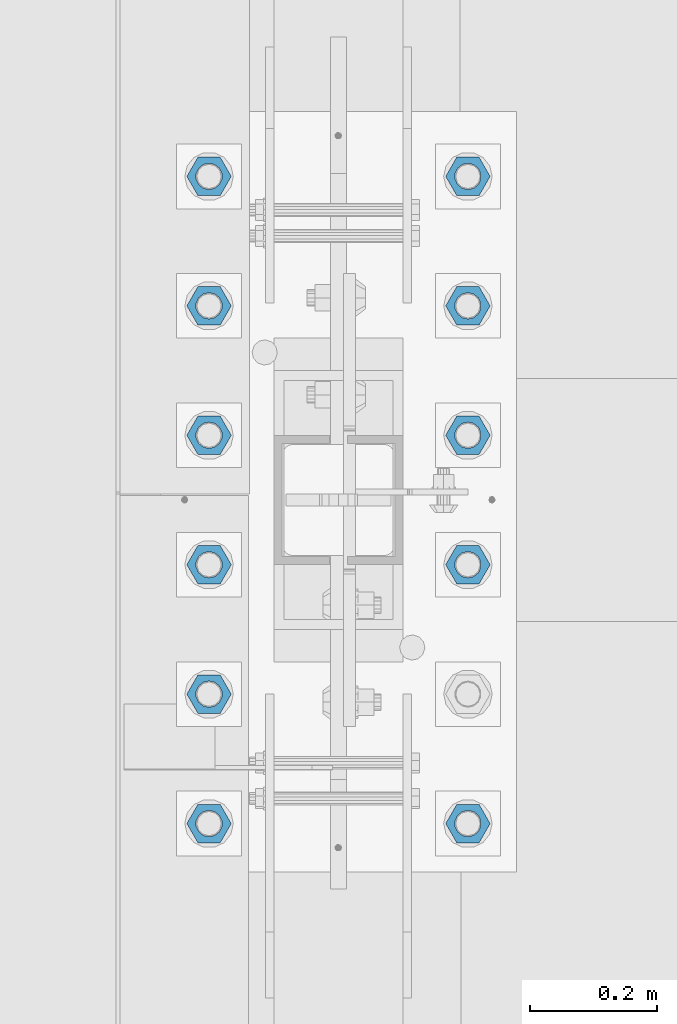
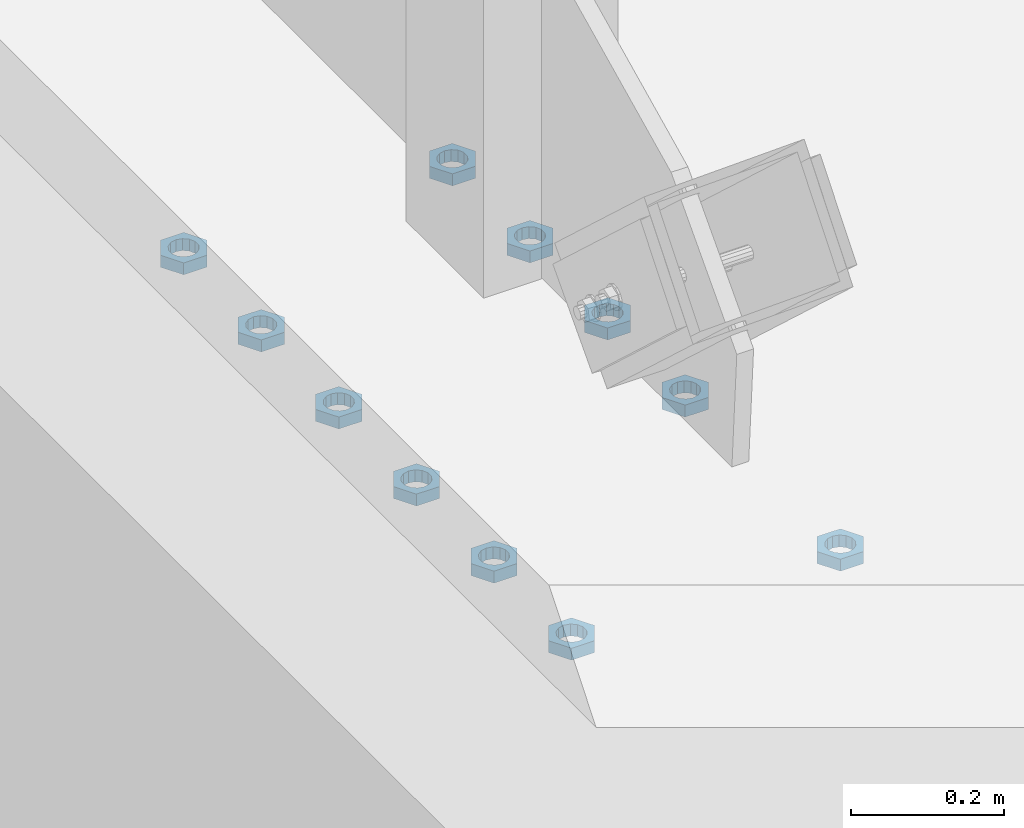
# One storey, part 1389 of 1763: 11 beams, 1 element without a shape of its own.
"""IFC2X3 building model written with IfcOpenShell, lengths in millimetres."""

import ifcopenshell
import ifcopenshell.guid

model = None  # the IFC model being written
_history = None  # IfcOwnerHistory: only IFC2X3 demands one
_inside = {}  # id of a spatial element -> (the spatial element, [elements in it])
_under = {}  # id of a project, library or spatial element -> (it, [spatial elements below it])
_declared = {}  # id of a project -> (the project, [libraries it declares])
_typed = {}  # id of a type object -> (the type object, [elements of that type])
_made_of = {}  # id of a material, layer set ... -> (it, [elements and type objects made of it])


def new_model(schema):
    """Start an empty IFC model of exactly this schema.

    Asked for "IFC4X3", IfcOpenShell would pick the latest addendum, in which some entities
    have other attributes; the version numbers below select the first issue.
    IFC2X3 requires an IfcOwnerHistory on every rooted entity: one is made here for all.
    """
    global model, _history
    if schema == "IFC4X3":
        model = ifcopenshell.file(schema_version=(4, 3, 0, 0))
    else:
        model = ifcopenshell.file(schema=schema)
    _inside.clear()
    _under.clear()
    _declared.clear()
    _typed.clear()
    _made_of.clear()
    _history = None
    if model.schema == "IFC2X3":
        org = make("IfcOrganization", Name="unknown")
        user = make(
            "IfcPersonAndOrganization",
            ThePerson=make("IfcPerson", FamilyName="unknown"),
            TheOrganization=org,
        )
        app = make(
            "IfcApplication",
            ApplicationDeveloper=org,
            Version="unknown",
            ApplicationFullName="unknown",
            ApplicationIdentifier="unknown",
        )
        _history = make(
            "IfcOwnerHistory",
            OwningUser=user,
            OwningApplication=app,
            ChangeAction="ADDED",
            CreationDate=0,
        )
    return model


def make(cls, **values):
    """One entity of the class cls with the attributes given. An attribute that is None is left unset."""
    return model.create_entity(
        cls, **{name: value for name, value in values.items() if value is not None}
    )


def rooted(cls, **values):
    """An entity with a GlobalId (a new one), such as an element, a storey or a relation."""
    return make(cls, GlobalId=ifcopenshell.guid.new(), OwnerHistory=_history, **values)


def si_unit(unit_type, name, prefix=None):
    """IfcSIUnit, for example si_unit("LENGTHUNIT", "METRE", prefix="MILLI")."""
    return make("IfcSIUnit", UnitType=unit_type, Prefix=prefix, Name=name)


def assignment(units):
    """IfcUnitAssignment: the units of a project."""
    return None if units is None else make("IfcUnitAssignment", Units=units)


def point(xyz):
    """IfcCartesianPoint."""
    return None if xyz is None else make("IfcCartesianPoint", Coordinates=xyz)


def direction(xyz):
    """IfcDirection."""
    return None if xyz is None else make("IfcDirection", DirectionRatios=xyz)


def frame(location, z_axis=None, x_axis=None):
    """IfcAxis2Placement3D, a coordinate frame: its origin and axes. An axis left out is left unset."""
    return make(
        "IfcAxis2Placement3D",
        Location=point(location),
        Axis=direction(z_axis),
        RefDirection=direction(x_axis),
    )


def origin_with_axes():
    """The frame at (0, 0, 0) with the z axis (0, 0, 1) and the x axis (1, 0, 0) written out."""
    return frame((0.0, 0.0, 0.0), z_axis=(0.0, 0.0, 1.0), x_axis=(1.0, 0.0, 0.0))


def place(relative_to, where):
    """IfcLocalPlacement: puts the frame where relative to a parent placement (None: the world)."""
    return make(
        "IfcLocalPlacement", PlacementRelTo=relative_to, RelativePlacement=where
    )


def context(
    kind, dimensions, precision=None, world=None, true_north=None, identifier=None
):
    """IfcGeometricRepresentationContext, for example the 3D "Model" context."""
    return make(
        "IfcGeometricRepresentationContext",
        ContextIdentifier=identifier,
        ContextType=kind,
        CoordinateSpaceDimension=dimensions,
        Precision=precision,
        WorldCoordinateSystem=world,
        TrueNorth=true_north,
    )


def subcontext(parent, identifier, kind, view, scale=None):
    """IfcGeometricRepresentationSubContext, for example "Body" below "Model"."""
    return make(
        "IfcGeometricRepresentationSubContext",
        ContextIdentifier=identifier,
        ContextType=kind,
        ParentContext=parent,
        TargetScale=scale,
        TargetView=view,
    )


def project(units=None, contexts=None):
    """IfcProject with its units and contexts."""
    return rooted(
        "IfcProject",
        Name="project",
        RepresentationContexts=contexts,
        UnitsInContext=assignment(units),
    )


def spatial(cls, under=None, at=None, **own):
    """A site, building, storey or space (cls), placed at a placement, below another one or the project."""
    s = rooted(cls, ObjectPlacement=at, **own)
    if under is not None:
        _under.setdefault(under.id(), (under, []))[1].append(s)
    return s


def faces_of(points, faces, orient=None, outer=None):
    """IfcFace entities. A face is a list of loops; a loop is a list of indices into points, from 0.

    orient and outer hold one flag for each loop. By default every Orientation is true, the
    first loop of a face is its IfcFaceOuterBound and the others are IfcFaceBound.
    """
    made = []
    for i, loops in enumerate(faces):
        bounds = []
        for j, loop in enumerate(loops):
            is_outer = j == 0 if outer is None else outer[i][j]
            bounds.append(
                make(
                    "IfcFaceOuterBound" if is_outer else "IfcFaceBound",
                    Bound=make("IfcPolyLoop", Polygon=[points[k] for k in loop]),
                    Orientation=True if orient is None else orient[i][j],
                )
            )
        made.append(make("IfcFace", Bounds=bounds))
    return made


def faceted_brep(points, faces, orient=None, outer=None, voids=None):
    """IfcFacetedBrep: a solid bounded by flat faces; with voids (closed shells), ...WithVoids."""
    shared = [point(p) for p in points]
    hull = make("IfcClosedShell", CfsFaces=faces_of(shared, faces, orient, outer))
    if voids is None:
        return make("IfcFacetedBrep", Outer=hull)
    return make(
        "IfcFacetedBrepWithVoids",
        Outer=hull,
        Voids=[
            make(cls, CfsFaces=faces_of(shared, fs, o, b)) for cls, fs, o, b in voids
        ],
    )


def shape(context_of_items, identifier, shape_type, items):
    """IfcShapeRepresentation: the items that make up one representation, for example the "Body"."""
    return make(
        "IfcShapeRepresentation",
        ContextOfItems=context_of_items,
        RepresentationIdentifier=identifier,
        RepresentationType=shape_type,
        Items=items,
    )


def material(Name=None, Category=None):
    """IfcMaterial."""
    return make("IfcMaterial", Name=Name, Category=Category)


def made_of(thing, what):
    """Note that an element or type object is made of a material, layer set ...; save() writes the relation."""
    if what is not None:
        _made_of.setdefault(what.id(), (what, []))[1].append(thing)
    return thing


def type_object(cls, material=None, **own):
    """A type object (cls), such as IfcWallType, which elements share."""
    return made_of(rooted(cls, **own), material)


def element(
    cls,
    number,
    at=None,
    inside=None,
    cuts=None,
    type_object=None,
    material=None,
    context=None,
    identifier="Body",
    shape_type=None,
    held_by="IfcProductDefinitionShape",
    body=None,
    shapes=None,
    **own,
):
    """One element of the class cls, such as IfcWall. Its Tag is "e" and its number.

    at: its placement. inside: the storey or other place that contains it. cuts: it is an
    opening in that element (IfcRelVoidsElement). A single representation is given by context,
    identifier, shape_type and body (its items); several are given by shapes. held_by: the class
    of the entity that holds the representations. save() writes the other relations.
    """
    e = rooted(cls, Tag="e%d" % number, ObjectPlacement=at, **own)
    if body is not None:
        shapes = [shape(context, identifier, shape_type, body)]
    if shapes is not None:
        e.Representation = make(held_by, Representations=shapes)
    if inside is not None:
        _inside.setdefault(inside.id(), (inside, []))[1].append(e)
    if cuts is not None:
        rooted(
            "IfcRelVoidsElement", RelatingBuildingElement=cuts, RelatedOpeningElement=e
        )
    if type_object is not None:
        _typed.setdefault(type_object.id(), (type_object, []))[1].append(e)
    return made_of(e, material)


def aggregate(whole, parts):
    """IfcRelAggregates: a whole, such as a stair, and the parts it consists of."""
    return rooted("IfcRelAggregates", RelatingObject=whole, RelatedObjects=parts)


def save(model, path):
    """Write the relations noted so far, then the file.

    IfcRelAggregates (storeys below a building ...), IfcRelContainedInSpatialStructure (elements
    in a storey), IfcRelDefinesByType, IfcRelAssociatesMaterial and IfcRelDeclares: one each for
    every whole, place, type object, material and project.
    """
    for whole, parts in _under.values():
        aggregate(whole, parts)
    for where, things in _inside.values():
        rooted(
            "IfcRelContainedInSpatialStructure",
            RelatedElements=things,
            RelatingStructure=where,
        )
    for kind, things in _typed.values():
        rooted("IfcRelDefinesByType", RelatedObjects=things, RelatingType=kind)
    for what, things in _made_of.values():
        rooted("IfcRelAssociatesMaterial", RelatedObjects=things, RelatingMaterial=what)
    for by, libraries in _declared.values():
        rooted("IfcRelDeclares", RelatingContext=by, RelatedDefinitions=libraries)
    model.write(path)


model = new_model("IFC2X3")

# Units and contexts
model_context = context("Model", 3, precision=1e-05, world=origin_with_axes())
body_context = subcontext(model_context, "Body", "Model", "MODEL_VIEW")
ifc_project = project(units=[si_unit("LENGTHUNIT", "METRE", prefix="MILLI"), si_unit("AREAUNIT", "SQUARE_METRE"), si_unit("VOLUMEUNIT", "CUBIC_METRE"), si_unit("MASSUNIT", "GRAM", prefix="KILO"), si_unit("TIMEUNIT", "SECOND"), si_unit("PLANEANGLEUNIT", "RADIAN"), si_unit("SOLIDANGLEUNIT", "STERADIAN"), si_unit("THERMODYNAMICTEMPERATUREUNIT", "DEGREE_CELSIUS"), si_unit("LUMINOUSINTENSITYUNIT", "LUMEN")], contexts=[model_context])

# Site, building, storey
site_placement = place(None, origin_with_axes())
site = spatial("IfcSite", under=ifc_project, at=site_placement, CompositionType="ELEMENT")
building_placement = place(site_placement, origin_with_axes())
building = spatial("IfcBuilding", under=site, at=building_placement, Name="Undefined", CompositionType="ELEMENT")
storey_placement = place(building_placement, origin_with_axes())
storey = spatial("IfcBuildingStorey", under=building, at=storey_placement, Name="Undefined", CompositionType="ELEMENT", Elevation=0.0)

# Assembly, beams
assembly_placement = place(storey_placement, origin_with_axes())
assembly = element("IfcElementAssembly", 1, at=assembly_placement, inside=storey, Name="TEMPLATE", AssemblyPlace="NOTDEFINED", PredefinedType="RIGID_FRAME")
ifc_material = material(Name="STEEL/A563")
beam_type = type_object("IfcBeamType", Name="1-1/2 DIA. HALF_NUT", PredefinedType="NOTDEFINED")
beam_1_placement = place(assembly_placement, frame((-87578.6372736983, 965.200000000001, 5080.0), z_axis=(0.0, -1.0, 0.0), x_axis=(0.0, 0.0, -1.0)))
beam_1 = element("IfcBeam", 2, at=beam_1_placement, type_object=beam_type, material=ifc_material, Name="NUT", ObjectType="1-1/2 DIA. HALF_NUT", context=body_context, shape_type="Brep", body=[
    faceted_brep([(0.0, -34.9199981689453, 0.0), (0.0, -17.4599990844727, -30.25), (19.0499999999993, -17.4599990844727, -30.25), (19.0499999999993, -34.9199981689453, 0.0), (0.0, 17.4599990844727, -30.25), (19.0499999999993, 17.4599990844727, -30.25), (0.0, 34.9199981689453, 0.0), (19.0499999999993, 34.9199981689453, 0.0), (0.0, 17.4599990844727, 30.25), (19.0499999999993, 17.4599990844727, 30.25), (0.0, -17.4599990844727, 30.25), (19.0499999999993, -17.4599990844727, 30.25), (0.0, 0.0, 20.6399993896484), (0.0, 8.95536011056538, 18.5959968835978), (19.0499999999993, 8.95536011056538, 18.5959968835978), (19.0499999999993, 0.0, 20.6399993896484), (0.0, 16.1370013209453, 12.8688291298167), (19.0499999999993, 16.1370013209453, 12.8688291298167), (0.0, 20.1225115123816, 4.59283194104137), (19.0499999999993, 20.1225115123816, 4.59283194104137), (0.0, 20.1225115123816, -4.59283194104319), (19.0499999999993, 20.1225115123816, -4.59283194104319), (0.0, 16.1370013209453, -12.8688291298167), (19.0499999999993, 16.1370013209453, -12.8688291298167), (0.0, 8.95536011056538, -18.5959968835978), (19.0499999999993, 8.95536011056538, -18.5959968835978), (0.0, 0.0, -20.6399993896484), (19.0499999999993, 0.0, -20.6399993896484), (0.0, -8.95536011056538, -18.5959968835978), (19.0499999999993, -8.95536011056538, -18.5959968835978), (0.0, -16.1370013209453, -12.8688291298167), (19.0499999999993, -16.1370013209453, -12.8688291298167), (0.0, -20.1225115123816, -4.59283194104137), (19.0499999999993, -20.1225115123816, -4.59283194104137), (0.0, -20.1225115123816, 4.59283194104319), (19.0499999999993, -20.1225115123816, 4.59283194104319), (0.0, -16.1370013209453, 12.8688291298167), (19.0499999999993, -16.1370013209453, 12.8688291298167), (0.0, -8.95536011056538, 18.5959968835978), (19.0499999999993, -8.95536011056538, 18.5959968835978)], [[[0, 1, 2, 3]], [[1, 4, 5, 2]], [[4, 6, 7, 5]], [[6, 8, 9, 7]], [[8, 10, 11, 9]], [[10, 0, 3, 11]], [[12, 13, 14, 15]], [[13, 16, 17, 14]], [[16, 18, 19, 17]], [[18, 20, 21, 19]], [[20, 22, 23, 21]], [[22, 24, 25, 23]], [[24, 26, 27, 25]], [[26, 28, 29, 27]], [[28, 30, 31, 29]], [[30, 32, 33, 31]], [[32, 34, 35, 33]], [[34, 36, 37, 35]], [[36, 38, 39, 37]], [[38, 12, 15, 39]], [[5, 7, 9, 11, 3, 2], [17, 19, 21, 23, 25, 27, 29, 31, 33, 35, 37, 39, 15, 14]], [[10, 8, 6, 4, 1, 0], [38, 36, 34, 32, 30, 28, 26, 24, 22, 20, 18, 16, 13, 12]]]),
])
beam_2_placement = place(assembly_placement, frame((-87578.6372736983, 762.000000000001, 5080.0), z_axis=(0.0, -1.0, 0.0), x_axis=(0.0, 0.0, -1.0)))
beam_2 = element("IfcBeam", 3, at=beam_2_placement, type_object=beam_type, material=ifc_material, Name="NUT", ObjectType="1-1/2 DIA. HALF_NUT", context=body_context, shape_type="Brep", body=[
    faceted_brep([(0.0, -34.9199981689453, 0.0), (0.0, -17.4599990844727, -30.25), (19.0499999999993, -17.4599990844727, -30.25), (19.0499999999993, -34.9199981689453, 0.0), (0.0, 17.4599990844727, -30.25), (19.0499999999993, 17.4599990844727, -30.25), (0.0, 34.9199981689453, 0.0), (19.0499999999993, 34.9199981689453, 0.0), (0.0, 17.4599990844727, 30.25), (19.0499999999993, 17.4599990844727, 30.25), (0.0, -17.4599990844727, 30.25), (19.0499999999993, -17.4599990844727, 30.25), (0.0, 0.0, 20.6399993896484), (0.0, 8.95536011056538, 18.5959968835978), (19.0499999999993, 8.95536011056538, 18.5959968835978), (19.0499999999993, 0.0, 20.6399993896484), (0.0, 16.1370013209453, 12.8688291298167), (19.0499999999993, 16.1370013209453, 12.8688291298167), (0.0, 20.1225115123816, 4.59283194104137), (19.0499999999993, 20.1225115123816, 4.59283194104137), (0.0, 20.1225115123816, -4.59283194104319), (19.0499999999993, 20.1225115123816, -4.59283194104319), (0.0, 16.1370013209453, -12.8688291298167), (19.0499999999993, 16.1370013209453, -12.8688291298167), (0.0, 8.95536011056538, -18.5959968835978), (19.0499999999993, 8.95536011056538, -18.5959968835978), (0.0, 0.0, -20.6399993896484), (19.0499999999993, 0.0, -20.6399993896484), (0.0, -8.95536011056538, -18.5959968835978), (19.0499999999993, -8.95536011056538, -18.5959968835978), (0.0, -16.1370013209453, -12.8688291298167), (19.0499999999993, -16.1370013209453, -12.8688291298167), (0.0, -20.1225115123816, -4.59283194104137), (19.0499999999993, -20.1225115123816, -4.59283194104137), (0.0, -20.1225115123816, 4.59283194104319), (19.0499999999993, -20.1225115123816, 4.59283194104319), (0.0, -16.1370013209453, 12.8688291298167), (19.0499999999993, -16.1370013209453, 12.8688291298167), (0.0, -8.95536011056538, 18.5959968835978), (19.0499999999993, -8.95536011056538, 18.5959968835978)], [[[0, 1, 2, 3]], [[1, 4, 5, 2]], [[4, 6, 7, 5]], [[6, 8, 9, 7]], [[8, 10, 11, 9]], [[10, 0, 3, 11]], [[12, 13, 14, 15]], [[13, 16, 17, 14]], [[16, 18, 19, 17]], [[18, 20, 21, 19]], [[20, 22, 23, 21]], [[22, 24, 25, 23]], [[24, 26, 27, 25]], [[26, 28, 29, 27]], [[28, 30, 31, 29]], [[30, 32, 33, 31]], [[32, 34, 35, 33]], [[34, 36, 37, 35]], [[36, 38, 39, 37]], [[38, 12, 15, 39]], [[5, 7, 9, 11, 3, 2], [17, 19, 21, 23, 25, 27, 29, 31, 33, 35, 37, 39, 15, 14]], [[10, 8, 6, 4, 1, 0], [38, 36, 34, 32, 30, 28, 26, 24, 22, 20, 18, 16, 13, 12]]]),
])
beam_3_placement = place(assembly_placement, frame((-87172.2372736984, 965.200000000001, 5080.0), z_axis=(0.0, 1.0, 0.0), x_axis=(0.0, 0.0, -1.0)))
beam_3 = element("IfcBeam", 4, at=beam_3_placement, type_object=beam_type, material=ifc_material, Name="NUT", ObjectType="1-1/2 DIA. HALF_NUT", context=body_context, shape_type="Brep", body=[
    faceted_brep([(0.0, -34.9199981689453, 0.0), (0.0, -17.4599990844727, -30.25), (19.0499999999993, -17.4599990844727, -30.25), (19.0499999999993, -34.9199981689453, 0.0), (0.0, 17.4599990844727, -30.25), (19.0499999999993, 17.4599990844727, -30.25), (0.0, 34.9199981689453, 0.0), (19.0499999999993, 34.9199981689453, 0.0), (0.0, 17.4599990844727, 30.25), (19.0499999999993, 17.4599990844727, 30.25), (0.0, -17.4599990844727, 30.25), (19.0499999999993, -17.4599990844727, 30.25), (0.0, 0.0, 20.6399993896484), (0.0, 8.95536011056538, 18.5959968835978), (19.0499999999993, 8.95536011056538, 18.5959968835978), (19.0499999999993, 0.0, 20.6399993896484), (0.0, 16.1370013209453, 12.8688291298167), (19.0499999999993, 16.1370013209453, 12.8688291298167), (0.0, 20.1225115123816, 4.59283194104137), (19.0499999999993, 20.1225115123816, 4.59283194104137), (0.0, 20.1225115123816, -4.59283194104319), (19.0499999999993, 20.1225115123816, -4.59283194104319), (0.0, 16.1370013209453, -12.8688291298167), (19.0499999999993, 16.1370013209453, -12.8688291298167), (0.0, 8.95536011056538, -18.5959968835978), (19.0499999999993, 8.95536011056538, -18.5959968835978), (0.0, 0.0, -20.6399993896484), (19.0499999999993, 0.0, -20.6399993896484), (0.0, -8.95536011056538, -18.5959968835978), (19.0499999999993, -8.95536011056538, -18.5959968835978), (0.0, -16.1370013209453, -12.8688291298167), (19.0499999999993, -16.1370013209453, -12.8688291298167), (0.0, -20.1225115123816, -4.59283194104137), (19.0499999999993, -20.1225115123816, -4.59283194104137), (0.0, -20.1225115123816, 4.59283194104319), (19.0499999999993, -20.1225115123816, 4.59283194104319), (0.0, -16.1370013209453, 12.8688291298167), (19.0499999999993, -16.1370013209453, 12.8688291298167), (0.0, -8.95536011056538, 18.5959968835978), (19.0499999999993, -8.95536011056538, 18.5959968835978)], [[[0, 1, 2, 3]], [[1, 4, 5, 2]], [[4, 6, 7, 5]], [[6, 8, 9, 7]], [[8, 10, 11, 9]], [[10, 0, 3, 11]], [[12, 13, 14, 15]], [[13, 16, 17, 14]], [[16, 18, 19, 17]], [[18, 20, 21, 19]], [[20, 22, 23, 21]], [[22, 24, 25, 23]], [[24, 26, 27, 25]], [[26, 28, 29, 27]], [[28, 30, 31, 29]], [[30, 32, 33, 31]], [[32, 34, 35, 33]], [[34, 36, 37, 35]], [[36, 38, 39, 37]], [[38, 12, 15, 39]], [[5, 7, 9, 11, 3, 2], [17, 19, 21, 23, 25, 27, 29, 31, 33, 35, 37, 39, 15, 14]], [[10, 8, 6, 4, 1, 0], [38, 36, 34, 32, 30, 28, 26, 24, 22, 20, 18, 16, 13, 12]]]),
])
beam_4_placement = place(assembly_placement, frame((-87578.6372736983, 558.800000000001, 5080.0), z_axis=(0.0, -1.0, 0.0), x_axis=(0.0, 0.0, -1.0)))
beam_4 = element("IfcBeam", 5, at=beam_4_placement, type_object=beam_type, material=ifc_material, Name="NUT", ObjectType="1-1/2 DIA. HALF_NUT", context=body_context, shape_type="Brep", body=[
    faceted_brep([(0.0, -34.9199981689453, 0.0), (0.0, -17.4599990844727, -30.25), (19.0499999999993, -17.4599990844727, -30.25), (19.0499999999993, -34.9199981689453, 0.0), (0.0, 17.4599990844727, -30.25), (19.0499999999993, 17.4599990844727, -30.25), (0.0, 34.9199981689453, 0.0), (19.0499999999993, 34.9199981689453, 0.0), (0.0, 17.4599990844727, 30.25), (19.0499999999993, 17.4599990844727, 30.25), (0.0, -17.4599990844727, 30.25), (19.0499999999993, -17.4599990844727, 30.25), (0.0, 0.0, 20.6399993896484), (0.0, 8.95536011056538, 18.5959968835978), (19.0499999999993, 8.95536011056538, 18.5959968835978), (19.0499999999993, 0.0, 20.6399993896484), (0.0, 16.1370013209453, 12.8688291298167), (19.0499999999993, 16.1370013209453, 12.8688291298167), (0.0, 20.1225115123816, 4.59283194104137), (19.0499999999993, 20.1225115123816, 4.59283194104137), (0.0, 20.1225115123816, -4.59283194104319), (19.0499999999993, 20.1225115123816, -4.59283194104319), (0.0, 16.1370013209453, -12.8688291298167), (19.0499999999993, 16.1370013209453, -12.8688291298167), (0.0, 8.95536011056538, -18.5959968835978), (19.0499999999993, 8.95536011056538, -18.5959968835978), (0.0, 0.0, -20.6399993896484), (19.0499999999993, 0.0, -20.6399993896484), (0.0, -8.95536011056538, -18.5959968835978), (19.0499999999993, -8.95536011056538, -18.5959968835978), (0.0, -16.1370013209453, -12.8688291298167), (19.0499999999993, -16.1370013209453, -12.8688291298167), (0.0, -20.1225115123816, -4.59283194104137), (19.0499999999993, -20.1225115123816, -4.59283194104137), (0.0, -20.1225115123816, 4.59283194104319), (19.0499999999993, -20.1225115123816, 4.59283194104319), (0.0, -16.1370013209453, 12.8688291298167), (19.0499999999993, -16.1370013209453, 12.8688291298167), (0.0, -8.95536011056538, 18.5959968835978), (19.0499999999993, -8.95536011056538, 18.5959968835978)], [[[0, 1, 2, 3]], [[1, 4, 5, 2]], [[4, 6, 7, 5]], [[6, 8, 9, 7]], [[8, 10, 11, 9]], [[10, 0, 3, 11]], [[12, 13, 14, 15]], [[13, 16, 17, 14]], [[16, 18, 19, 17]], [[18, 20, 21, 19]], [[20, 22, 23, 21]], [[22, 24, 25, 23]], [[24, 26, 27, 25]], [[26, 28, 29, 27]], [[28, 30, 31, 29]], [[30, 32, 33, 31]], [[32, 34, 35, 33]], [[34, 36, 37, 35]], [[36, 38, 39, 37]], [[38, 12, 15, 39]], [[5, 7, 9, 11, 3, 2], [17, 19, 21, 23, 25, 27, 29, 31, 33, 35, 37, 39, 15, 14]], [[10, 8, 6, 4, 1, 0], [38, 36, 34, 32, 30, 28, 26, 24, 22, 20, 18, 16, 13, 12]]]),
])
beam_5_placement = place(assembly_placement, frame((-87172.2372736984, 762.000000000001, 5080.0), z_axis=(0.0, 1.0, 0.0), x_axis=(0.0, 0.0, -1.0)))
beam_5 = element("IfcBeam", 6, at=beam_5_placement, type_object=beam_type, material=ifc_material, Name="NUT", ObjectType="1-1/2 DIA. HALF_NUT", context=body_context, shape_type="Brep", body=[
    faceted_brep([(0.0, -34.9199981689453, 0.0), (0.0, -17.4599990844727, -30.25), (19.0499999999993, -17.4599990844727, -30.25), (19.0499999999993, -34.9199981689453, 0.0), (0.0, 17.4599990844727, -30.25), (19.0499999999993, 17.4599990844727, -30.25), (0.0, 34.9199981689453, 0.0), (19.0499999999993, 34.9199981689453, 0.0), (0.0, 17.4599990844727, 30.25), (19.0499999999993, 17.4599990844727, 30.25), (0.0, -17.4599990844727, 30.25), (19.0499999999993, -17.4599990844727, 30.25), (0.0, 0.0, 20.6399993896484), (0.0, 8.95536011056538, 18.5959968835978), (19.0499999999993, 8.95536011056538, 18.5959968835978), (19.0499999999993, 0.0, 20.6399993896484), (0.0, 16.1370013209453, 12.8688291298167), (19.0499999999993, 16.1370013209453, 12.8688291298167), (0.0, 20.1225115123816, 4.59283194104137), (19.0499999999993, 20.1225115123816, 4.59283194104137), (0.0, 20.1225115123816, -4.59283194104319), (19.0499999999993, 20.1225115123816, -4.59283194104319), (0.0, 16.1370013209453, -12.8688291298167), (19.0499999999993, 16.1370013209453, -12.8688291298167), (0.0, 8.95536011056538, -18.5959968835978), (19.0499999999993, 8.95536011056538, -18.5959968835978), (0.0, 0.0, -20.6399993896484), (19.0499999999993, 0.0, -20.6399993896484), (0.0, -8.95536011056538, -18.5959968835978), (19.0499999999993, -8.95536011056538, -18.5959968835978), (0.0, -16.1370013209453, -12.8688291298167), (19.0499999999993, -16.1370013209453, -12.8688291298167), (0.0, -20.1225115123816, -4.59283194104137), (19.0499999999993, -20.1225115123816, -4.59283194104137), (0.0, -20.1225115123816, 4.59283194104319), (19.0499999999993, -20.1225115123816, 4.59283194104319), (0.0, -16.1370013209453, 12.8688291298167), (19.0499999999993, -16.1370013209453, 12.8688291298167), (0.0, -8.95536011056538, 18.5959968835978), (19.0499999999993, -8.95536011056538, 18.5959968835978)], [[[0, 1, 2, 3]], [[1, 4, 5, 2]], [[4, 6, 7, 5]], [[6, 8, 9, 7]], [[8, 10, 11, 9]], [[10, 0, 3, 11]], [[12, 13, 14, 15]], [[13, 16, 17, 14]], [[16, 18, 19, 17]], [[18, 20, 21, 19]], [[20, 22, 23, 21]], [[22, 24, 25, 23]], [[24, 26, 27, 25]], [[26, 28, 29, 27]], [[28, 30, 31, 29]], [[30, 32, 33, 31]], [[32, 34, 35, 33]], [[34, 36, 37, 35]], [[36, 38, 39, 37]], [[38, 12, 15, 39]], [[5, 7, 9, 11, 3, 2], [17, 19, 21, 23, 25, 27, 29, 31, 33, 35, 37, 39, 15, 14]], [[10, 8, 6, 4, 1, 0], [38, 36, 34, 32, 30, 28, 26, 24, 22, 20, 18, 16, 13, 12]]]),
])
beam_6_placement = place(assembly_placement, frame((-87578.6372736983, 355.600000000001, 5080.0), z_axis=(0.0, -1.0, 0.0), x_axis=(0.0, 0.0, -1.0)))
beam_6 = element("IfcBeam", 7, at=beam_6_placement, type_object=beam_type, material=ifc_material, Name="NUT", ObjectType="1-1/2 DIA. HALF_NUT", context=body_context, shape_type="Brep", body=[
    faceted_brep([(0.0, -34.9199981689453, 0.0), (0.0, -17.4599990844727, -30.25), (19.0499999999993, -17.4599990844727, -30.25), (19.0499999999993, -34.9199981689453, 0.0), (0.0, 17.4599990844727, -30.25), (19.0499999999993, 17.4599990844727, -30.25), (0.0, 34.9199981689453, 0.0), (19.0499999999993, 34.9199981689453, 0.0), (0.0, 17.4599990844727, 30.25), (19.0499999999993, 17.4599990844727, 30.25), (0.0, -17.4599990844727, 30.25), (19.0499999999993, -17.4599990844727, 30.25), (0.0, 0.0, 20.6399993896484), (0.0, 8.95536011056538, 18.5959968835978), (19.0499999999993, 8.95536011056538, 18.5959968835978), (19.0499999999993, 0.0, 20.6399993896484), (0.0, 16.1370013209453, 12.8688291298167), (19.0499999999993, 16.1370013209453, 12.8688291298167), (0.0, 20.1225115123816, 4.59283194104137), (19.0499999999993, 20.1225115123816, 4.59283194104137), (0.0, 20.1225115123816, -4.59283194104319), (19.0499999999993, 20.1225115123816, -4.59283194104319), (0.0, 16.1370013209453, -12.8688291298167), (19.0499999999993, 16.1370013209453, -12.8688291298167), (0.0, 8.95536011056538, -18.5959968835978), (19.0499999999993, 8.95536011056538, -18.5959968835978), (0.0, 0.0, -20.6399993896484), (19.0499999999993, 0.0, -20.6399993896484), (0.0, -8.95536011056538, -18.5959968835978), (19.0499999999993, -8.95536011056538, -18.5959968835978), (0.0, -16.1370013209453, -12.8688291298167), (19.0499999999993, -16.1370013209453, -12.8688291298167), (0.0, -20.1225115123816, -4.59283194104137), (19.0499999999993, -20.1225115123816, -4.59283194104137), (0.0, -20.1225115123816, 4.59283194104319), (19.0499999999993, -20.1225115123816, 4.59283194104319), (0.0, -16.1370013209453, 12.8688291298167), (19.0499999999993, -16.1370013209453, 12.8688291298167), (0.0, -8.95536011056538, 18.5959968835978), (19.0499999999993, -8.95536011056538, 18.5959968835978)], [[[0, 1, 2, 3]], [[1, 4, 5, 2]], [[4, 6, 7, 5]], [[6, 8, 9, 7]], [[8, 10, 11, 9]], [[10, 0, 3, 11]], [[12, 13, 14, 15]], [[13, 16, 17, 14]], [[16, 18, 19, 17]], [[18, 20, 21, 19]], [[20, 22, 23, 21]], [[22, 24, 25, 23]], [[24, 26, 27, 25]], [[26, 28, 29, 27]], [[28, 30, 31, 29]], [[30, 32, 33, 31]], [[32, 34, 35, 33]], [[34, 36, 37, 35]], [[36, 38, 39, 37]], [[38, 12, 15, 39]], [[5, 7, 9, 11, 3, 2], [17, 19, 21, 23, 25, 27, 29, 31, 33, 35, 37, 39, 15, 14]], [[10, 8, 6, 4, 1, 0], [38, 36, 34, 32, 30, 28, 26, 24, 22, 20, 18, 16, 13, 12]]]),
])
beam_7_placement = place(assembly_placement, frame((-87172.2372736984, 558.800000000001, 5080.0), z_axis=(0.0, 1.0, 0.0), x_axis=(0.0, 0.0, -1.0)))
beam_7 = element("IfcBeam", 8, at=beam_7_placement, type_object=beam_type, material=ifc_material, Name="NUT", ObjectType="1-1/2 DIA. HALF_NUT", context=body_context, shape_type="Brep", body=[
    faceted_brep([(0.0, -34.9199981689453, 0.0), (0.0, -17.4599990844727, -30.25), (19.0499999999993, -17.4599990844727, -30.25), (19.0499999999993, -34.9199981689453, 0.0), (0.0, 17.4599990844727, -30.25), (19.0499999999993, 17.4599990844727, -30.25), (0.0, 34.9199981689453, 0.0), (19.0499999999993, 34.9199981689453, 0.0), (0.0, 17.4599990844727, 30.25), (19.0499999999993, 17.4599990844727, 30.25), (0.0, -17.4599990844727, 30.25), (19.0499999999993, -17.4599990844727, 30.25), (0.0, 0.0, 20.6399993896484), (0.0, 8.95536011056538, 18.5959968835978), (19.0499999999993, 8.95536011056538, 18.5959968835978), (19.0499999999993, 0.0, 20.6399993896484), (0.0, 16.1370013209453, 12.8688291298167), (19.0499999999993, 16.1370013209453, 12.8688291298167), (0.0, 20.1225115123816, 4.59283194104137), (19.0499999999993, 20.1225115123816, 4.59283194104137), (0.0, 20.1225115123816, -4.59283194104319), (19.0499999999993, 20.1225115123816, -4.59283194104319), (0.0, 16.1370013209453, -12.8688291298167), (19.0499999999993, 16.1370013209453, -12.8688291298167), (0.0, 8.95536011056538, -18.5959968835978), (19.0499999999993, 8.95536011056538, -18.5959968835978), (0.0, 0.0, -20.6399993896484), (19.0499999999993, 0.0, -20.6399993896484), (0.0, -8.95536011056538, -18.5959968835978), (19.0499999999993, -8.95536011056538, -18.5959968835978), (0.0, -16.1370013209453, -12.8688291298167), (19.0499999999993, -16.1370013209453, -12.8688291298167), (0.0, -20.1225115123816, -4.59283194104137), (19.0499999999993, -20.1225115123816, -4.59283194104137), (0.0, -20.1225115123816, 4.59283194104319), (19.0499999999993, -20.1225115123816, 4.59283194104319), (0.0, -16.1370013209453, 12.8688291298167), (19.0499999999993, -16.1370013209453, 12.8688291298167), (0.0, -8.95536011056538, 18.5959968835978), (19.0499999999993, -8.95536011056538, 18.5959968835978)], [[[0, 1, 2, 3]], [[1, 4, 5, 2]], [[4, 6, 7, 5]], [[6, 8, 9, 7]], [[8, 10, 11, 9]], [[10, 0, 3, 11]], [[12, 13, 14, 15]], [[13, 16, 17, 14]], [[16, 18, 19, 17]], [[18, 20, 21, 19]], [[20, 22, 23, 21]], [[22, 24, 25, 23]], [[24, 26, 27, 25]], [[26, 28, 29, 27]], [[28, 30, 31, 29]], [[30, 32, 33, 31]], [[32, 34, 35, 33]], [[34, 36, 37, 35]], [[36, 38, 39, 37]], [[38, 12, 15, 39]], [[5, 7, 9, 11, 3, 2], [17, 19, 21, 23, 25, 27, 29, 31, 33, 35, 37, 39, 15, 14]], [[10, 8, 6, 4, 1, 0], [38, 36, 34, 32, 30, 28, 26, 24, 22, 20, 18, 16, 13, 12]]]),
])
beam_8_placement = place(assembly_placement, frame((-87578.6372736983, 152.400000000001, 5080.0), z_axis=(0.0, -1.0, 0.0), x_axis=(0.0, 0.0, -1.0)))
beam_8 = element("IfcBeam", 9, at=beam_8_placement, type_object=beam_type, material=ifc_material, Name="NUT", ObjectType="1-1/2 DIA. HALF_NUT", context=body_context, shape_type="Brep", body=[
    faceted_brep([(0.0, -34.9199981689453, 0.0), (0.0, -17.4599990844727, -30.25), (19.0499999999993, -17.4599990844727, -30.25), (19.0499999999993, -34.9199981689453, 0.0), (0.0, 17.4599990844727, -30.25), (19.0499999999993, 17.4599990844727, -30.25), (0.0, 34.9199981689453, 0.0), (19.0499999999993, 34.9199981689453, 0.0), (0.0, 17.4599990844727, 30.25), (19.0499999999993, 17.4599990844727, 30.25), (0.0, -17.4599990844727, 30.25), (19.0499999999993, -17.4599990844727, 30.25), (0.0, 0.0, 20.6399993896484), (0.0, 8.95536011056538, 18.5959968835978), (19.0499999999993, 8.95536011056538, 18.5959968835978), (19.0499999999993, 0.0, 20.6399993896484), (0.0, 16.1370013209453, 12.8688291298167), (19.0499999999993, 16.1370013209453, 12.8688291298167), (0.0, 20.1225115123816, 4.59283194104137), (19.0499999999993, 20.1225115123816, 4.59283194104137), (0.0, 20.1225115123816, -4.59283194104319), (19.0499999999993, 20.1225115123816, -4.59283194104319), (0.0, 16.1370013209453, -12.8688291298167), (19.0499999999993, 16.1370013209453, -12.8688291298167), (0.0, 8.95536011056538, -18.5959968835978), (19.0499999999993, 8.95536011056538, -18.5959968835978), (0.0, 0.0, -20.6399993896484), (19.0499999999993, 0.0, -20.6399993896484), (0.0, -8.95536011056538, -18.5959968835978), (19.0499999999993, -8.95536011056538, -18.5959968835978), (0.0, -16.1370013209453, -12.8688291298167), (19.0499999999993, -16.1370013209453, -12.8688291298167), (0.0, -20.1225115123816, -4.59283194104137), (19.0499999999993, -20.1225115123816, -4.59283194104137), (0.0, -20.1225115123816, 4.59283194104319), (19.0499999999993, -20.1225115123816, 4.59283194104319), (0.0, -16.1370013209453, 12.8688291298167), (19.0499999999993, -16.1370013209453, 12.8688291298167), (0.0, -8.95536011056538, 18.5959968835978), (19.0499999999993, -8.95536011056538, 18.5959968835978)], [[[0, 1, 2, 3]], [[1, 4, 5, 2]], [[4, 6, 7, 5]], [[6, 8, 9, 7]], [[8, 10, 11, 9]], [[10, 0, 3, 11]], [[12, 13, 14, 15]], [[13, 16, 17, 14]], [[16, 18, 19, 17]], [[18, 20, 21, 19]], [[20, 22, 23, 21]], [[22, 24, 25, 23]], [[24, 26, 27, 25]], [[26, 28, 29, 27]], [[28, 30, 31, 29]], [[30, 32, 33, 31]], [[32, 34, 35, 33]], [[34, 36, 37, 35]], [[36, 38, 39, 37]], [[38, 12, 15, 39]], [[5, 7, 9, 11, 3, 2], [17, 19, 21, 23, 25, 27, 29, 31, 33, 35, 37, 39, 15, 14]], [[10, 8, 6, 4, 1, 0], [38, 36, 34, 32, 30, 28, 26, 24, 22, 20, 18, 16, 13, 12]]]),
])
beam_9_placement = place(assembly_placement, frame((-87172.2372736984, 355.600000000001, 5080.0), z_axis=(0.0, 1.0, 0.0), x_axis=(0.0, 0.0, -1.0)))
beam_9 = element("IfcBeam", 10, at=beam_9_placement, type_object=beam_type, material=ifc_material, Name="NUT", ObjectType="1-1/2 DIA. HALF_NUT", context=body_context, shape_type="Brep", body=[
    faceted_brep([(0.0, -34.9199981689453, 0.0), (0.0, -17.4599990844727, -30.25), (19.0499999999993, -17.4599990844727, -30.25), (19.0499999999993, -34.9199981689453, 0.0), (0.0, 17.4599990844727, -30.25), (19.0499999999993, 17.4599990844727, -30.25), (0.0, 34.9199981689453, 0.0), (19.0499999999993, 34.9199981689453, 0.0), (0.0, 17.4599990844727, 30.25), (19.0499999999993, 17.4599990844727, 30.25), (0.0, -17.4599990844727, 30.25), (19.0499999999993, -17.4599990844727, 30.25), (0.0, 0.0, 20.6399993896484), (0.0, 8.95536011056538, 18.5959968835978), (19.0499999999993, 8.95536011056538, 18.5959968835978), (19.0499999999993, 0.0, 20.6399993896484), (0.0, 16.1370013209453, 12.8688291298167), (19.0499999999993, 16.1370013209453, 12.8688291298167), (0.0, 20.1225115123816, 4.59283194104137), (19.0499999999993, 20.1225115123816, 4.59283194104137), (0.0, 20.1225115123816, -4.59283194104319), (19.0499999999993, 20.1225115123816, -4.59283194104319), (0.0, 16.1370013209453, -12.8688291298167), (19.0499999999993, 16.1370013209453, -12.8688291298167), (0.0, 8.95536011056538, -18.5959968835978), (19.0499999999993, 8.95536011056538, -18.5959968835978), (0.0, 0.0, -20.6399993896484), (19.0499999999993, 0.0, -20.6399993896484), (0.0, -8.95536011056538, -18.5959968835978), (19.0499999999993, -8.95536011056538, -18.5959968835978), (0.0, -16.1370013209453, -12.8688291298167), (19.0499999999993, -16.1370013209453, -12.8688291298167), (0.0, -20.1225115123816, -4.59283194104137), (19.0499999999993, -20.1225115123816, -4.59283194104137), (0.0, -20.1225115123816, 4.59283194104319), (19.0499999999993, -20.1225115123816, 4.59283194104319), (0.0, -16.1370013209453, 12.8688291298167), (19.0499999999993, -16.1370013209453, 12.8688291298167), (0.0, -8.95536011056538, 18.5959968835978), (19.0499999999993, -8.95536011056538, 18.5959968835978)], [[[0, 1, 2, 3]], [[1, 4, 5, 2]], [[4, 6, 7, 5]], [[6, 8, 9, 7]], [[8, 10, 11, 9]], [[10, 0, 3, 11]], [[12, 13, 14, 15]], [[13, 16, 17, 14]], [[16, 18, 19, 17]], [[18, 20, 21, 19]], [[20, 22, 23, 21]], [[22, 24, 25, 23]], [[24, 26, 27, 25]], [[26, 28, 29, 27]], [[28, 30, 31, 29]], [[30, 32, 33, 31]], [[32, 34, 35, 33]], [[34, 36, 37, 35]], [[36, 38, 39, 37]], [[38, 12, 15, 39]], [[5, 7, 9, 11, 3, 2], [17, 19, 21, 23, 25, 27, 29, 31, 33, 35, 37, 39, 15, 14]], [[10, 8, 6, 4, 1, 0], [38, 36, 34, 32, 30, 28, 26, 24, 22, 20, 18, 16, 13, 12]]]),
])
beam_10_placement = place(assembly_placement, frame((-87172.2372736984, -50.7999999999993, 5080.0), z_axis=(0.0, 1.0, 0.0), x_axis=(0.0, 0.0, -1.0)))
beam_10 = element("IfcBeam", 11, at=beam_10_placement, type_object=beam_type, material=ifc_material, Name="NUT", ObjectType="1-1/2 DIA. HALF_NUT", context=body_context, shape_type="Brep", body=[
    faceted_brep([(0.0, -34.9199981689453, 0.0), (0.0, -17.4599990844727, -30.25), (19.0499999999993, -17.4599990844727, -30.25), (19.0499999999993, -34.9199981689453, 0.0), (0.0, 17.4599990844727, -30.25), (19.0499999999993, 17.4599990844727, -30.25), (0.0, 34.9199981689453, 0.0), (19.0499999999993, 34.9199981689453, 0.0), (0.0, 17.4599990844727, 30.25), (19.0499999999993, 17.4599990844727, 30.25), (0.0, -17.4599990844727, 30.25), (19.0499999999993, -17.4599990844727, 30.25), (0.0, 0.0, 20.6399993896484), (0.0, 8.95536011056538, 18.5959968835978), (19.0499999999993, 8.95536011056538, 18.5959968835978), (19.0499999999993, 0.0, 20.6399993896484), (0.0, 16.1370013209453, 12.8688291298167), (19.0499999999993, 16.1370013209453, 12.8688291298167), (0.0, 20.1225115123816, 4.59283194104137), (19.0499999999993, 20.1225115123816, 4.59283194104137), (0.0, 20.1225115123816, -4.59283194104319), (19.0499999999993, 20.1225115123816, -4.59283194104319), (0.0, 16.1370013209453, -12.8688291298167), (19.0499999999993, 16.1370013209453, -12.8688291298167), (0.0, 8.95536011056538, -18.5959968835978), (19.0499999999993, 8.95536011056538, -18.5959968835978), (0.0, 0.0, -20.6399993896484), (19.0499999999993, 0.0, -20.6399993896484), (0.0, -8.95536011056538, -18.5959968835978), (19.0499999999993, -8.95536011056538, -18.5959968835978), (0.0, -16.1370013209453, -12.8688291298167), (19.0499999999993, -16.1370013209453, -12.8688291298167), (0.0, -20.1225115123816, -4.59283194104137), (19.0499999999993, -20.1225115123816, -4.59283194104137), (0.0, -20.1225115123816, 4.59283194104319), (19.0499999999993, -20.1225115123816, 4.59283194104319), (0.0, -16.1370013209453, 12.8688291298167), (19.0499999999993, -16.1370013209453, 12.8688291298167), (0.0, -8.95536011056538, 18.5959968835978), (19.0499999999993, -8.95536011056538, 18.5959968835978)], [[[0, 1, 2, 3]], [[1, 4, 5, 2]], [[4, 6, 7, 5]], [[6, 8, 9, 7]], [[8, 10, 11, 9]], [[10, 0, 3, 11]], [[12, 13, 14, 15]], [[13, 16, 17, 14]], [[16, 18, 19, 17]], [[18, 20, 21, 19]], [[20, 22, 23, 21]], [[22, 24, 25, 23]], [[24, 26, 27, 25]], [[26, 28, 29, 27]], [[28, 30, 31, 29]], [[30, 32, 33, 31]], [[32, 34, 35, 33]], [[34, 36, 37, 35]], [[36, 38, 39, 37]], [[38, 12, 15, 39]], [[5, 7, 9, 11, 3, 2], [17, 19, 21, 23, 25, 27, 29, 31, 33, 35, 37, 39, 15, 14]], [[10, 8, 6, 4, 1, 0], [38, 36, 34, 32, 30, 28, 26, 24, 22, 20, 18, 16, 13, 12]]]),
])
beam_11_placement = place(assembly_placement, frame((-87578.6372736983, -50.7999999999993, 5080.0), z_axis=(0.0, -1.0, 0.0), x_axis=(0.0, 0.0, -1.0)))
beam_11 = element("IfcBeam", 12, at=beam_11_placement, type_object=beam_type, material=ifc_material, Name="NUT", ObjectType="1-1/2 DIA. HALF_NUT", context=body_context, shape_type="Brep", body=[
    faceted_brep([(0.0, -34.9199981689453, 0.0), (0.0, -17.4599990844727, -30.25), (19.0499999999993, -17.4599990844727, -30.25), (19.0499999999993, -34.9199981689453, 0.0), (0.0, 17.4599990844727, -30.25), (19.0499999999993, 17.4599990844727, -30.25), (0.0, 34.9199981689453, 0.0), (19.0499999999993, 34.9199981689453, 0.0), (0.0, 17.4599990844727, 30.25), (19.0499999999993, 17.4599990844727, 30.25), (0.0, -17.4599990844727, 30.25), (19.0499999999993, -17.4599990844727, 30.25), (0.0, 0.0, 20.6399993896484), (0.0, 8.95536011056538, 18.5959968835978), (19.0499999999993, 8.95536011056538, 18.5959968835978), (19.0499999999993, 0.0, 20.6399993896484), (0.0, 16.1370013209453, 12.8688291298167), (19.0499999999993, 16.1370013209453, 12.8688291298167), (0.0, 20.1225115123816, 4.59283194104137), (19.0499999999993, 20.1225115123816, 4.59283194104137), (0.0, 20.1225115123816, -4.59283194104319), (19.0499999999993, 20.1225115123816, -4.59283194104319), (0.0, 16.1370013209453, -12.8688291298167), (19.0499999999993, 16.1370013209453, -12.8688291298167), (0.0, 8.95536011056538, -18.5959968835978), (19.0499999999993, 8.95536011056538, -18.5959968835978), (0.0, 0.0, -20.6399993896484), (19.0499999999993, 0.0, -20.6399993896484), (0.0, -8.95536011056538, -18.5959968835978), (19.0499999999993, -8.95536011056538, -18.5959968835978), (0.0, -16.1370013209453, -12.8688291298167), (19.0499999999993, -16.1370013209453, -12.8688291298167), (0.0, -20.1225115123816, -4.59283194104137), (19.0499999999993, -20.1225115123816, -4.59283194104137), (0.0, -20.1225115123816, 4.59283194104319), (19.0499999999993, -20.1225115123816, 4.59283194104319), (0.0, -16.1370013209453, 12.8688291298167), (19.0499999999993, -16.1370013209453, 12.8688291298167), (0.0, -8.95536011056538, 18.5959968835978), (19.0499999999993, -8.95536011056538, 18.5959968835978)], [[[0, 1, 2, 3]], [[1, 4, 5, 2]], [[4, 6, 7, 5]], [[6, 8, 9, 7]], [[8, 10, 11, 9]], [[10, 0, 3, 11]], [[12, 13, 14, 15]], [[13, 16, 17, 14]], [[16, 18, 19, 17]], [[18, 20, 21, 19]], [[20, 22, 23, 21]], [[22, 24, 25, 23]], [[24, 26, 27, 25]], [[26, 28, 29, 27]], [[28, 30, 31, 29]], [[30, 32, 33, 31]], [[32, 34, 35, 33]], [[34, 36, 37, 35]], [[36, 38, 39, 37]], [[38, 12, 15, 39]], [[5, 7, 9, 11, 3, 2], [17, 19, 21, 23, 25, 27, 29, 31, 33, 35, 37, 39, 15, 14]], [[10, 8, 6, 4, 1, 0], [38, 36, 34, 32, 30, 28, 26, 24, 22, 20, 18, 16, 13, 12]]]),
])
aggregate(assembly, [beam_1, beam_2, beam_3, beam_4, beam_5, beam_6, beam_7, beam_8, beam_9, beam_10, beam_11])

save(model, "model.ifc")
